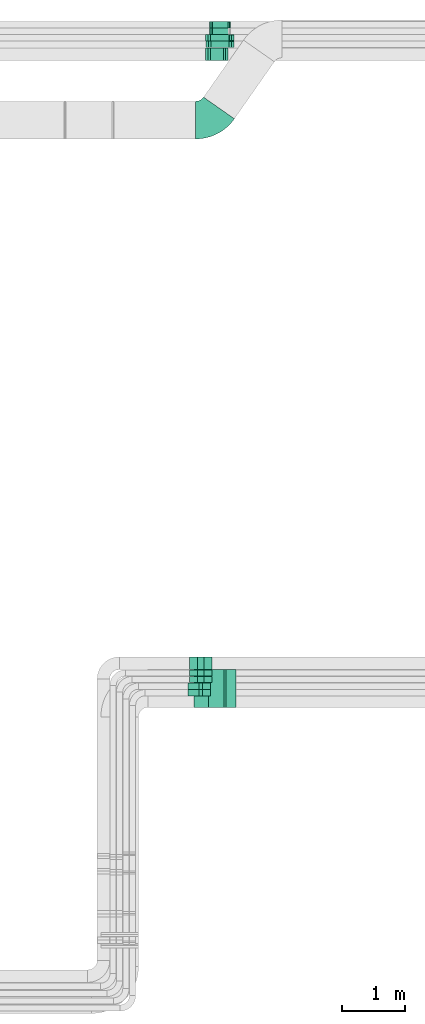
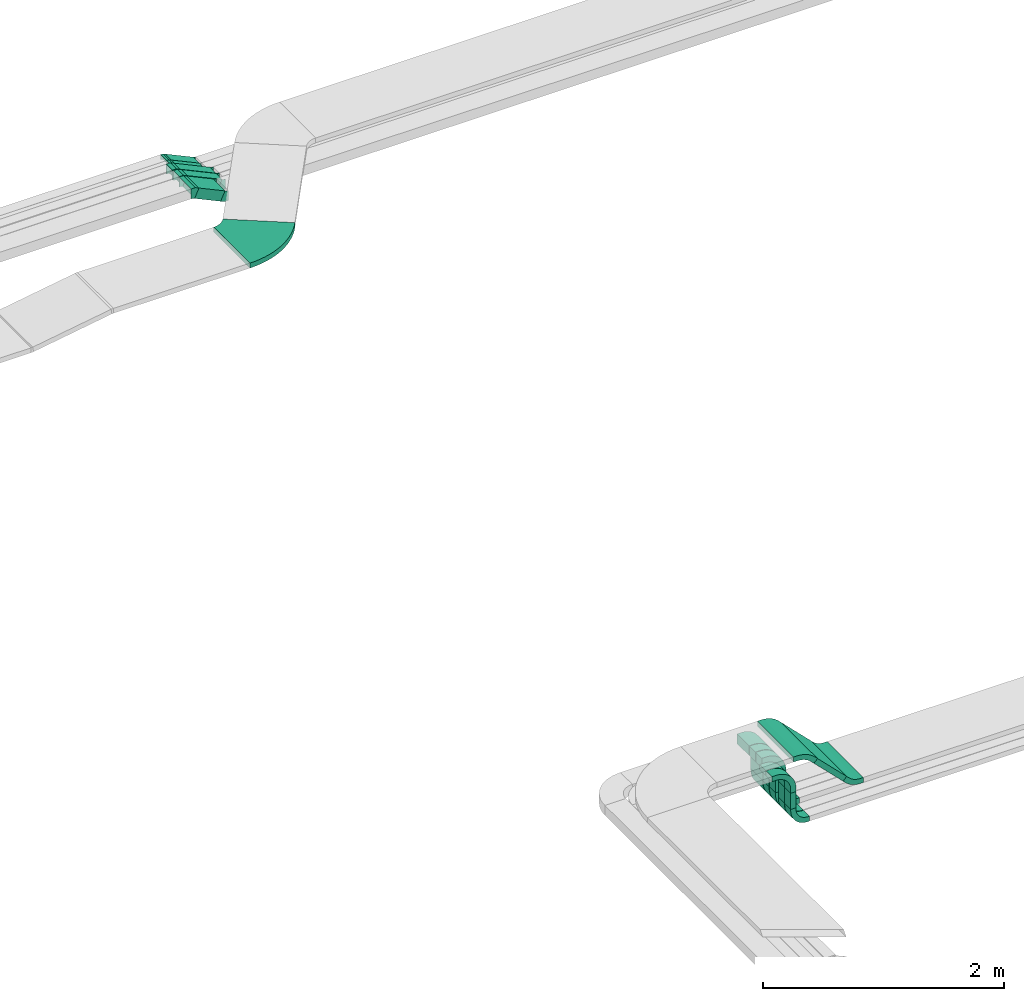
# One storey, part 20 of 28: 22 flow fittings, 11 flow segments.
"""IFC2X3 building model written with IfcOpenShell, lengths in millimetres."""

from ifc_helpers import new_model, entity, si_unit, converted_unit, derived_unit, direction, frame, frame_2d, origin, origin_2d_with_axis, place, context, subcontext, project, spatial, polyline, circle_curve, parameter, trimmed, segment, composite_curve, rectangle, outline, extrude, faceted_brep, source, transform, mapped, material, type_object, type_shapes, element, save


model = new_model("IFC2X3")

# Units and contexts
model_context = context("Model", 3, precision=0.01, world=origin(), true_north=direction((6.12303176911189e-17, 1.0)))
body_context = subcontext(model_context, "Body", "Model", "MODEL_VIEW")
ifc_project = project(units=[si_unit("LENGTHUNIT", "METRE", prefix="MILLI"), si_unit("AREAUNIT", "SQUARE_METRE"), si_unit("VOLUMEUNIT", "CUBIC_METRE"), converted_unit("PLANEANGLEUNIT", "DEGREE", entity("IfcRatioMeasure", 0.0174532925199433), si_unit("PLANEANGLEUNIT", "RADIAN"), dimensions=[0, 0, 0, 0, 0, 0, 0]), si_unit("MASSUNIT", "GRAM", prefix="KILO"), derived_unit("MASSDENSITYUNIT", [(si_unit("MASSUNIT", "GRAM", prefix="KILO"), 1), (si_unit("LENGTHUNIT", "METRE"), -3)]), derived_unit("MOMENTOFINERTIAUNIT", [(si_unit("LENGTHUNIT", "METRE"), 4)]), si_unit("TIMEUNIT", "SECOND"), si_unit("FREQUENCYUNIT", "HERTZ"), si_unit("THERMODYNAMICTEMPERATUREUNIT", "DEGREE_CELSIUS"), derived_unit("THERMALTRANSMITTANCEUNIT", [(si_unit("MASSUNIT", "GRAM", prefix="KILO"), 1), (si_unit("THERMODYNAMICTEMPERATUREUNIT", "KELVIN"), -1), (si_unit("TIMEUNIT", "SECOND"), -3)]), derived_unit("VOLUMETRICFLOWRATEUNIT", [(si_unit("LENGTHUNIT", "METRE"), 3), (si_unit("TIMEUNIT", "SECOND"), -1)]), derived_unit("MASSFLOWRATEUNIT", [(si_unit("MASSUNIT", "GRAM", prefix="KILO"), 1), (si_unit("TIMEUNIT", "SECOND"), -1)]), derived_unit("ROTATIONALFREQUENCYUNIT", [(si_unit("TIMEUNIT", "SECOND"), -1)]), si_unit("ELECTRICCURRENTUNIT", "AMPERE"), si_unit("ELECTRICVOLTAGEUNIT", "VOLT"), si_unit("POWERUNIT", "WATT"), si_unit("FORCEUNIT", "NEWTON", prefix="KILO"), si_unit("ILLUMINANCEUNIT", "LUX"), si_unit("LUMINOUSFLUXUNIT", "LUMEN"), si_unit("LUMINOUSINTENSITYUNIT", "CANDELA"), derived_unit("USERDEFINED", [(si_unit("MASSUNIT", "GRAM", prefix="KILO"), -1), (si_unit("LENGTHUNIT", "METRE"), -2), (si_unit("TIMEUNIT", "SECOND"), 3), (si_unit("LUMINOUSFLUXUNIT", "LUMEN"), 1)]), derived_unit("LINEARVELOCITYUNIT", [(si_unit("LENGTHUNIT", "METRE"), 1), (si_unit("TIMEUNIT", "SECOND"), -1)]), si_unit("PRESSUREUNIT", "PASCAL"), derived_unit("USERDEFINED", [(si_unit("LENGTHUNIT", "METRE"), -2), (si_unit("MASSUNIT", "GRAM", prefix="KILO"), 1), (si_unit("TIMEUNIT", "SECOND"), -2)]), derived_unit("LINEARFORCEUNIT", [(si_unit("MASSUNIT", "GRAM", prefix="KILO"), 1), (si_unit("LENGTHUNIT", "METRE"), 1), (si_unit("TIMEUNIT", "SECOND"), -2), (si_unit("LENGTHUNIT", "METRE"), -1)]), derived_unit("PLANARFORCEUNIT", [(si_unit("MASSUNIT", "GRAM", prefix="KILO"), 1), (si_unit("LENGTHUNIT", "METRE"), 1), (si_unit("TIMEUNIT", "SECOND"), -2), (si_unit("LENGTHUNIT", "METRE"), -2)])], contexts=[model_context])

# Site, building, storey
site_placement = place(None, origin())
site = spatial("IfcSite", under=ifc_project, at=site_placement, CompositionType="ELEMENT")
building_placement = place(site_placement, origin())
building = spatial("IfcBuilding", under=site, at=building_placement, CompositionType="ELEMENT")
storey_placement = place(building_placement, frame((0.0, 0.0, 4200.0)))
storey = spatial("IfcBuildingStorey", under=building, at=storey_placement, CompositionType="ELEMENT", Elevation=4200.0)

# Flow segments
cable_carrier_segment_type = type_object("IfcCableCarrierSegmentType", PredefinedType="CABLETRAYSEGMENT")
flow_segment_1_placement = place(storey_placement, frame((40491.87, 5216.66, 2940.27)))
element("IfcFlowSegment", 1, at=flow_segment_1_placement, inside=storey, type_object=cable_carrier_segment_type, context=body_context, shape_type="SweptSolid", body=[
    extrude(rectangle(XDim=394.712516352665, YDim=49.9999999999872, at=origin_2d_with_axis()), frame((157.23, 0.0, 157.23), z_axis=(0.0, 1.0, 0.0), x_axis=(0.707106781186491, 0.0, -0.707106781186604)), (0.0, 0.0, 1.0), 600.0),
])
for number, where in (
    (2, (40376.18, 5400.19, 2680.0)),
    (3, (40376.18, 5505.19, 2680.0)),
):
    element("IfcFlowSegment", number, at=place(storey_placement, frame(where)), inside=storey, type_object=cable_carrier_segment_type, context=body_context, shape_type="SweptSolid", body=[
        extrude(rectangle(XDim=99.9999999999989, YDim=50.000000000006, at=origin_2d_with_axis()), frame((25.0, 50.0, 0.0), z_axis=(0.0, 0.0, 1.0), x_axis=(0.0, -1.0, 0.0)), (0.0, 0.0, 1.0), 165.00000000001),
    ])
flow_segment_2_placement = place(storey_placement, frame((40351.18, 5610.19, 2730.0)))
element("IfcFlowSegment", 4, at=flow_segment_2_placement, inside=storey, type_object=cable_carrier_segment_type, context=body_context, shape_type="SweptSolid", body=[
    extrude(rectangle(XDim=100.000000000001, YDim=99.9999999999946, at=origin_2d_with_axis()), frame((50.0, 50.0, 0.0), z_axis=(0.0, 0.0, 1.0), x_axis=(0.0, -1.0, 0.0)), (0.0, 0.0, 1.0), 165.000000000004),
])
flow_segment_3_placement = place(storey_placement, frame((40351.18, 5715.19, 2730.0)))
element("IfcFlowSegment", 5, at=flow_segment_3_placement, inside=storey, type_object=cable_carrier_segment_type, context=body_context, shape_type="SweptSolid", body=[
    extrude(rectangle(XDim=99.9999999999989, YDim=99.9999999999946, at=origin_2d_with_axis()), frame((50.0, 50.0, 0.0), z_axis=(0.0, 0.0, 1.0), x_axis=(0.0, -1.0, 0.0)), (0.0, 0.0, 1.0), 164.999999999999),
])
flow_segment_4_placement = place(storey_placement, frame((40351.18, 5820.37, 2730.0)))
element("IfcFlowSegment", 6, at=flow_segment_4_placement, inside=storey, type_object=cable_carrier_segment_type, context=body_context, shape_type="SweptSolid", body=[
    extrude(rectangle(XDim=200.0, YDim=99.9999999999946, at=origin_2d_with_axis()), frame((50.0, 100.0, 0.0), z_axis=(0.0, 0.0, 1.0), x_axis=(0.0, -1.0, 0.0)), (0.0, 0.0, 1.0), 165.000000000017),
])
flow_segment_5_placement = place(storey_placement, frame((40513.14, 15519.49, 2563.34)))
element("IfcFlowSegment", 7, at=flow_segment_5_placement, inside=storey, type_object=cable_carrier_segment_type, context=body_context, shape_type="SweptSolid", body=[
    extrude(rectangle(XDim=100.000000000005, YDim=200.000000000002, at=origin_2d_with_axis()), frame((21.13, 100.0, 161.41), z_axis=(0.906307787036662, 0.0, -0.422618261740674), x_axis=(0.422618261740674, 0.0, 0.906307787036662)), (0.0, 0.0, 1.0), 274.712342486454),
])
flow_segment_6_placement = place(storey_placement, frame((40522.14, 15728.42, 2520.51)))
element("IfcFlowSegment", 8, at=flow_segment_6_placement, inside=storey, type_object=cable_carrier_segment_type, context=body_context, shape_type="SweptSolid", body=[
    extrude(rectangle(XDim=99.9999999999933, YDim=99.9999999999989, at=origin_2d_with_axis()), frame((21.13, 50.0, 200.05), z_axis=(0.90630778703668, 0.0, -0.422618261740636), x_axis=(0.422618261740636, 0.0, 0.90630778703668)), (0.0, 0.0, 1.0), 366.132160564234),
])
flow_segment_7_placement = place(storey_placement, frame((40513.14, 15833.42, 2520.07)))
element("IfcFlowSegment", 9, at=flow_segment_7_placement, inside=storey, type_object=cable_carrier_segment_type, context=body_context, shape_type="SweptSolid", body=[
    extrude(rectangle(XDim=99.9999999999969, YDim=99.9999999999989, at=origin_2d_with_axis()), frame((21.13, 50.0, 204.68), z_axis=(0.906307787036647, 0.0, -0.422618261740707), x_axis=(0.422618261740707, 0.0, 0.906307787036647)), (0.0, 0.0, 1.0), 377.094354823424),
])
flow_segment_8_placement = place(storey_placement, frame((40567.27, 15938.42, 2556.31)))
element("IfcFlowSegment", 10, at=flow_segment_8_placement, inside=storey, type_object=cable_carrier_segment_type, context=body_context, shape_type="SweptSolid", body=[
    extrude(rectangle(XDim=50.0000000000057, YDim=99.9999999999989, at=origin_2d_with_axis()), frame((10.57, 50.0, 148.13), z_axis=(0.906307787036635, 0.0, -0.422618261740732), x_axis=(0.422618261740732, 0.0, 0.906307787036635)), (0.0, 0.0, 1.0), 296.896682553644),
])
flow_segment_9_placement = place(storey_placement, frame((40567.27, 16039.18, 2556.31)))
element("IfcFlowSegment", 11, at=flow_segment_9_placement, inside=storey, type_object=cable_carrier_segment_type, context=body_context, shape_type="SweptSolid", body=[
    extrude(rectangle(XDim=50.0000000000047, YDim=99.9999999999989, at=origin_2d_with_axis()), frame((10.57, 50.0, 148.13), z_axis=(0.906307787036631, 0.0, -0.422618261740741), x_axis=(0.422618261740741, 0.0, 0.906307787036631)), (0.0, 0.0, 1.0), 296.881808750623),
])

# Flow fittings
ifc_material = material()
cable_carrier_fitting_type_1 = type_object("IfcCableCarrierFittingType", PredefinedType="NOTDEFINED", material=ifc_material)
shared_shape_1 = source(origin(), body_context, "Body", "Brep", [
    faceted_brep([(-28.28, -50.0, 100.0), (-28.28, 50.0, 100.0), (-28.28, 50.0, 97.46), (-28.28, -47.46, 97.46), (-28.28, -47.46, -97.46), (-28.28, 50.0, -97.46), (-28.28, 50.0, -100.0), (-28.28, -50.0, -100.0), (46.76, -33.36, 100.0), (46.76, -33.36, -100.0), (4.5, 57.27, -100.0), (4.5, 57.27, -97.46), (45.69, -31.06, -97.46), (45.69, -31.06, 97.46), (4.5, 57.27, 97.46), (4.5, 57.27, 100.0), (11.08, -50.0, 100.0), (-11.08, 50.0, 100.0), (-11.08, 50.0, 97.46), (10.52, -47.46, 97.46), (10.52, -47.46, -97.46), (-11.08, 50.0, -97.46), (-11.08, 50.0, -100.0), (11.08, -50.0, -100.0)], [[[0, 1, 2, 3, 4, 5, 6, 7]], [[8, 9, 10, 11, 12, 13, 14, 15]], [[1, 0, 16, 8, 15, 17]], [[2, 1, 17, 18]], [[3, 2, 18, 14, 13, 19]], [[4, 3, 19, 20]], [[5, 4, 20, 12, 11, 21]], [[6, 5, 21, 22]], [[7, 6, 22, 10, 9, 23]], [[0, 7, 23, 16]], [[18, 17, 15, 14]], [[20, 19, 13, 12]], [[22, 21, 11, 10]], [[16, 23, 9, 8]]]),
])
type_shapes(cable_carrier_fitting_type_1, [shared_shape_1])
for number, where, z_axis, x_axis in (
    (12, (40808.87, 15619.49, 2596.71), (0.0, 1.0, 0.0), (-1.0, 0.0, 0.0)),
    (13, (40508.64, 15619.49, 2736.71), (0.0, -1.0, 0.0), (-0.906307787036659, 0.0, 0.42261826174068)),
):
    element("IfcFlowFitting", number, at=place(storey_placement, frame(where, z_axis=z_axis, x_axis=x_axis)), inside=storey, type_object=cable_carrier_fitting_type_1, material=ifc_material, context=body_context, shape_type="MappedRepresentation", body=[
        mapped(shared_shape_1, transform((0.0, 0.0, 0.0), scale=1.0)),
    ])
cable_carrier_fitting_type_2 = type_object("IfcCableCarrierFittingType", PredefinedType="NOTDEFINED", material=ifc_material)
shared_shape_2 = source(origin(), body_context, "Body", "Brep", [
    faceted_brep([(-28.28, -50.0, 50.0), (-28.28, 50.0, 50.0), (-28.28, 50.0, 47.46), (-28.28, -47.46, 47.46), (-28.28, -47.46, -47.46), (-28.28, 50.0, -47.46), (-28.28, 50.0, -50.0), (-28.28, -50.0, -50.0), (46.76, -33.36, 50.0), (46.76, -33.36, -50.0), (4.5, 57.27, -50.0), (4.5, 57.27, -47.46), (45.69, -31.06, -47.46), (45.69, -31.06, 47.46), (4.5, 57.27, 47.46), (4.5, 57.27, 50.0), (11.08, -50.0, 50.0), (-11.08, 50.0, 50.0), (-11.08, 50.0, 47.46), (10.52, -47.46, 47.46), (10.52, -47.46, -47.46), (-11.08, 50.0, -47.46), (-11.08, 50.0, -50.0), (11.08, -50.0, -50.0)], [[[0, 1, 2, 3, 4, 5, 6, 7]], [[8, 9, 10, 11, 12, 13, 14, 15]], [[1, 0, 16, 8, 15, 17]], [[2, 1, 17, 18]], [[3, 2, 18, 14, 13, 19]], [[4, 3, 19, 20]], [[5, 4, 20, 12, 11, 21]], [[6, 5, 21, 22]], [[7, 6, 22, 10, 9, 23]], [[0, 7, 23, 16]], [[18, 17, 15, 14]], [[20, 19, 13, 12]], [[22, 21, 11, 10]], [[16, 23, 9, 8]]]),
])
type_shapes(cable_carrier_fitting_type_2, [shared_shape_2])
for number, where, z_axis, x_axis in (
    (14, (40900.72, 15778.42, 2553.87), (0.0, -1.0, 0.0), (0.906307787036655, 0.0, -0.422618261740689)),
    (15, (40517.64, 15778.42, 2732.51), (0.0, -1.0, 0.0), (-0.906307787036656, 0.0, 0.422618261740687)),
    (16, (40901.66, 15883.42, 2553.44), (0.0, -1.0, 0.0), (0.906307787036657, 0.0, -0.422618261740685)),
    (17, (40508.64, 15883.42, 2736.71), (0.0, -1.0, 0.0), (-0.906307787036657, 0.0, 0.422618261740684)),
):
    element("IfcFlowFitting", number, at=place(storey_placement, frame(where, z_axis=z_axis, x_axis=x_axis)), inside=storey, type_object=cable_carrier_fitting_type_2, material=ifc_material, context=body_context, shape_type="MappedRepresentation", body=[
        mapped(shared_shape_2, transform((0.0, 0.0, 0.0), scale=1.0)),
    ])
cable_carrier_fitting_type_3 = type_object("IfcCableCarrierFittingType", PredefinedType="NOTDEFINED", material=ifc_material)
shared_shape_3 = source(origin(), body_context, "Body", "Brep", [
    faceted_brep([(-17.19, -25.0, 50.0), (-17.19, 25.0, 50.0), (-17.19, 25.0, 47.46), (-17.19, -22.46, 47.46), (-17.19, -22.46, -47.46), (-17.19, 25.0, -47.46), (-17.19, 25.0, -50.0), (-17.19, -25.0, -50.0), (26.15, -15.39, 50.0), (26.15, -15.39, -50.0), (5.02, 29.92, -50.0), (5.02, 29.92, -47.46), (25.07, -13.09, -47.46), (25.07, -13.09, 47.46), (5.02, 29.92, 47.46), (5.02, 29.92, 50.0), (5.54, -25.0, 50.0), (-5.54, 25.0, 50.0), (-5.54, 25.0, 47.46), (4.98, -22.46, 47.46), (4.98, -22.46, -47.46), (-5.54, 25.0, -47.46), (-5.54, 25.0, -50.0), (5.54, -25.0, -50.0)], [[[0, 1, 2, 3, 4, 5, 6, 7]], [[8, 9, 10, 11, 12, 13, 14, 15]], [[1, 0, 16, 8, 15, 17]], [[2, 1, 17, 18]], [[3, 2, 18, 14, 13, 19]], [[4, 3, 19, 20]], [[5, 4, 20, 12, 11, 21]], [[6, 5, 21, 22]], [[7, 6, 22, 10, 9, 23]], [[0, 7, 23, 16]], [[18, 17, 15, 14]], [[20, 19, 13, 12]], [[22, 21, 11, 10]], [[16, 23, 9, 8]]]),
])
type_shapes(cable_carrier_fitting_type_3, [shared_shape_3])
for number, where, z_axis, x_axis in (
    (18, (40862.48, 16089.18, 2571.71), (0.0, -1.0, 0.0), (0.906307787036659, 0.0, -0.42261826174068)),
    (19, (40562.25, 15988.42, 2711.71), (0.0, -1.0, 0.0), (-0.906307787036662, 0.0, 0.422618261740673)),
    (20, (40562.25, 16089.18, 2711.71), (0.0, -1.0, 0.0), (-0.906307787036652, 0.0, 0.422618261740696)),
):
    element("IfcFlowFitting", number, at=place(storey_placement, frame(where, z_axis=z_axis, x_axis=x_axis)), inside=storey, type_object=cable_carrier_fitting_type_3, material=ifc_material, context=body_context, shape_type="MappedRepresentation", body=[
        mapped(shared_shape_3, transform((0.0, 0.0, 0.0), scale=1.0)),
    ])
cable_carrier_fitting_type_4 = type_object("IfcCableCarrierFittingType", Name="470_DKC_S5_CD 90 external vertical angle:-", PredefinedType="NOTDEFINED", material=ifc_material)
shared_shape_4 = source(origin(), body_context, "Body", "SweptSolid", [
    extrude(outline(composite_curve([segment(polyline([(-100.0, -130.0), (-60.0, -130.0)]), True, "CONTINUOUS"), segment(trimmed(circle_curve(frame_2d((-60.0, 60.0), x_axis=(0.0, -1.0)), 189.999999999999), [parameter(0.0)], [parameter(90.0)], True, "PARAMETER"), True, "CONTINUOUS"), segment(polyline([(130.0, 60.0), (130.0, 100.0)]), True, "CONTINUOUS"), segment(polyline([(130.0, 100.0), (30.0, 100.0)]), True, "CONTINUOUS"), segment(polyline([(30.0, 100.0), (30.0, 60.0)]), True, "CONTINUOUS"), segment(trimmed(circle_curve(frame_2d((-60.0, 60.0), x_axis=(0.0, -1.0)), 89.9999999999988), [parameter(0.0)], [parameter(90.0)], True, "PARAMETER"), False, "CONTINUOUS"), segment(polyline([(-60.0, -30.0), (-100.0, -30.0)]), True, "CONTINUOUS"), segment(polyline([(-100.0, -30.0), (-100.0, -130.0)]), True, "CONTINUOUS")], self_intersect=False)), frame((-80.0, 80.0, -50.0)), (0.0, 0.0, 1.0), 99.9999999999999),
])
type_shapes(cable_carrier_fitting_type_4, [shared_shape_4])
for number, where, z_axis, x_axis, name in (
    (21, (40401.18, 5660.19, 3075.0), (0.0, -1.0, 0.0), (0.0, 0.0, 1.0), "470_DKC_S5_CD 90 external vertical angle:-"),
    (22, (40401.18, 5765.19, 3075.0), (0.0, -1.0, 0.0), (0.0, 0.0, 1.0), "470_DKC_S5_CD 90 external vertical angle:-"),
):
    element("IfcFlowFitting", number, at=place(storey_placement, frame(where, z_axis=z_axis, x_axis=x_axis)), inside=storey, type_object=cable_carrier_fitting_type_4, material=ifc_material, Name=name, ObjectType="470_DKC_S5_CD 90 external vertical angle:-", context=body_context, shape_type="MappedRepresentation", body=[
        mapped(shared_shape_4, transform((0.0, 0.0, 0.0), scale=1.0)),
    ])
cable_carrier_fitting_type_5 = type_object("IfcCableCarrierFittingType", Name="470_DKC_S5_Variable Angle Elbow 0-45:-", PredefinedType="NOTDEFINED", material=ifc_material)
shared_shape_5 = source(origin(), body_context, "Body", "SweptSolid", [
    extrude(outline(composite_curve([segment(polyline([(-185.2, -396.15), (-184.2, -396.15)]), True, "CONTINUOUS"), segment(trimmed(circle_curve(frame_2d((-184.2, 353.85), x_axis=(0.0, -1.0)), 750.0), [parameter(0.0)], [parameter(55.0)], True, "PARAMETER"), True, "CONTINUOUS"), segment(polyline([(430.16, -76.33), (430.74, -75.51)]), True, "CONTINUOUS"), segment(polyline([(430.74, -75.51), (-60.76, 268.63)]), True, "CONTINUOUS"), segment(polyline([(-60.76, 268.63), (-61.33, 267.81)]), True, "CONTINUOUS"), segment(trimmed(circle_curve(frame_2d((-184.2, 353.85), x_axis=(0.0, -1.0)), 150.0), [parameter(0.0)], [parameter(55.0)], True, "PARAMETER"), False, "CONTINUOUS"), segment(polyline([(-184.2, 203.85), (-185.2, 203.85)]), True, "CONTINUOUS"), segment(polyline([(-185.2, 203.85), (-185.2, -396.15)]), True, "CONTINUOUS")], self_intersect=False)), frame((-50.05, 96.15, -25.0)), (0.0, 0.0, 1.0), 50.0000000000068),
])
type_shapes(cable_carrier_fitting_type_5, [shared_shape_5])
flow_fitting_1_placement = place(storey_placement, frame((40557.3, 14571.85, 2823.17)))
element("IfcFlowFitting", 23, at=flow_fitting_1_placement, inside=storey, type_object=cable_carrier_fitting_type_5, material=ifc_material, Name="470_DKC_S5_Variable Angle Elbow 0-45:-", ObjectType="470_DKC_S5_Variable Angle Elbow 0-45:-", context=body_context, shape_type="MappedRepresentation", body=[
    mapped(shared_shape_5, transform((0.0, 0.0, 0.0), scale=1.0)),
])
cable_carrier_fitting_type_6 = type_object("IfcCableCarrierFittingType", Name="470_DKC_S5_CD 90 external vertical angle:-", PredefinedType="NOTDEFINED", material=ifc_material)
shared_shape_6 = source(origin(), body_context, "Body", "SweptSolid", [
    extrude(outline(composite_curve([segment(polyline([(-108.75, -62.73), (-73.43, -62.73)]), True, "CONTINUOUS"), segment(trimmed(circle_curve(frame_2d((-73.43, 177.27), x_axis=(0.0, -1.0)), 239.999999999999), [parameter(0.0)], [parameter(45.0)], True, "PARAMETER"), True, "CONTINUOUS"), segment(polyline([(96.28, 7.56), (121.25, 32.54)]), True, "CONTINUOUS"), segment(polyline([(121.25, 32.54), (85.9, 67.89)]), True, "CONTINUOUS"), segment(polyline([(85.9, 67.89), (60.92, 42.92)]), True, "CONTINUOUS"), segment(trimmed(circle_curve(frame_2d((-73.43, 177.27), x_axis=(0.0, -1.0)), 189.999999999999), [parameter(0.0)], [parameter(45.0)], True, "PARAMETER"), False, "CONTINUOUS"), segment(polyline([(-73.43, -12.73), (-108.75, -12.73)]), True, "CONTINUOUS"), segment(polyline([(-108.75, -12.73), (-108.75, -62.73)]), True, "CONTINUOUS")], self_intersect=False)), frame((-15.63, 37.73, -300.0)), (0.0, 0.0, 1.0), 600.0),
])
type_shapes(cable_carrier_fitting_type_6, [shared_shape_6])
flow_fitting_2_placement = place(storey_placement, frame((40421.6, 5516.66, 3325.0), z_axis=(0.0, 1.0, 0.0), x_axis=(1.0, 0.0, 0.0)))
element("IfcFlowFitting", 24, at=flow_fitting_2_placement, inside=storey, type_object=cable_carrier_fitting_type_6, material=ifc_material, Name="470_DKC_S5_CD 90 external vertical angle:-", ObjectType="470_DKC_S5_CD 90 external vertical angle:-", context=body_context, shape_type="MappedRepresentation", body=[
    mapped(shared_shape_6, transform((0.0, 0.0, 0.0), scale=1.0)),
])
cable_carrier_fitting_type_7 = type_object("IfcCableCarrierFittingType", Name="470_DKC_S5_CD 90 external vertical angle:-", PredefinedType="NOTDEFINED", material=ifc_material)
shared_shape_7 = source(origin(), body_context, "Body", "SweptSolid", [
    extrude(outline(composite_curve([segment(polyline([(-112.5, -117.5), (-72.5, -117.5)]), True, "CONTINUOUS"), segment(trimmed(circle_curve(frame_2d((-72.5, 72.5), x_axis=(0.0, -1.0)), 189.999999999999), [parameter(0.0)], [parameter(90.0)], True, "PARAMETER"), True, "CONTINUOUS"), segment(polyline([(117.5, 72.5), (117.5, 112.5)]), True, "CONTINUOUS"), segment(polyline([(117.5, 112.5), (67.5, 112.5)]), True, "CONTINUOUS"), segment(polyline([(67.5, 112.5), (67.5, 72.5)]), True, "CONTINUOUS"), segment(trimmed(circle_curve(frame_2d((-72.5, 72.5), x_axis=(0.0, -1.0)), 139.999999999999), [parameter(0.0)], [parameter(90.0)], True, "PARAMETER"), False, "CONTINUOUS"), segment(polyline([(-72.5, -67.5), (-112.5, -67.5)]), True, "CONTINUOUS"), segment(polyline([(-112.5, -67.5), (-112.5, -117.5)]), True, "CONTINUOUS")], self_intersect=False)), frame((-92.5, 92.5, -50.0)), (0.0, 0.0, 1.0), 99.9999999999999),
])
type_shapes(cable_carrier_fitting_type_7, [shared_shape_7])
for number, where, z_axis, x_axis, name in (
    (25, (40401.18, 5450.19, 3050.0), (0.0, -1.0, 0.0), (0.0, 0.0, 1.0), "470_DKC_S5_CD 90 external vertical angle:-"),
    (26, (40401.18, 5555.19, 3050.0), (0.0, -1.0, 0.0), (0.0, 0.0, 1.0), "470_DKC_S5_CD 90 external vertical angle:-"),
):
    element("IfcFlowFitting", number, at=place(storey_placement, frame(where, z_axis=z_axis, x_axis=x_axis)), inside=storey, type_object=cable_carrier_fitting_type_7, material=ifc_material, Name=name, ObjectType="470_DKC_S5_CD 90 external vertical angle:-", context=body_context, shape_type="MappedRepresentation", body=[
        mapped(shared_shape_7, transform((0.0, 0.0, 0.0), scale=1.0)),
    ])
cable_carrier_fitting_type_8 = type_object("IfcCableCarrierFittingType", Name="470_DKC_S5_CS 90 internal vertical angle:-", PredefinedType="NOTDEFINED", material=ifc_material)
shared_shape_8 = source(origin(), body_context, "Body", "SweptSolid", [
    extrude(outline(composite_curve([segment(polyline([(-81.25, -98.75), (-66.25, -98.75)]), True, "CONTINUOUS"), segment(trimmed(circle_curve(frame_2d((-66.25, 66.25), x_axis=(0.0, -1.0)), 164.999999999999), [parameter(0.0)], [parameter(90.0)], True, "PARAMETER"), True, "CONTINUOUS"), segment(polyline([(98.75, 66.25), (98.75, 81.25)]), True, "CONTINUOUS"), segment(polyline([(98.75, 81.25), (48.75, 81.25)]), True, "CONTINUOUS"), segment(polyline([(48.75, 81.25), (48.75, 66.25)]), True, "CONTINUOUS"), segment(trimmed(circle_curve(frame_2d((-66.25, 66.25), x_axis=(0.0, -1.0)), 114.999999999999), [parameter(0.0)], [parameter(90.0)], True, "PARAMETER"), False, "CONTINUOUS"), segment(polyline([(-66.25, -48.75), (-81.25, -48.75)]), True, "CONTINUOUS"), segment(polyline([(-81.25, -48.75), (-81.25, -98.75)]), True, "CONTINUOUS")], self_intersect=False)), frame((-73.75, 73.75, -50.0)), (0.0, 0.0, 1.0), 99.9999999999999),
])
type_shapes(cable_carrier_fitting_type_8, [shared_shape_8])
for number, where, z_axis, x_axis, name in (
    (27, (40401.18, 5555.19, 2525.0), (0.0, -1.0, 0.0), (0.0, 0.0, -1.0), "470_DKC_S5_CS 90 internal vertical angle:-"),
    (28, (40401.18, 5450.19, 2525.0), (0.0, -1.0, 0.0), (0.0, 0.0, -1.0), "470_DKC_S5_CS 90 internal vertical angle:-"),
):
    element("IfcFlowFitting", number, at=place(storey_placement, frame(where, z_axis=z_axis, x_axis=x_axis)), inside=storey, type_object=cable_carrier_fitting_type_8, material=ifc_material, Name=name, ObjectType="470_DKC_S5_CS 90 internal vertical angle:-", context=body_context, shape_type="MappedRepresentation", body=[
        mapped(shared_shape_8, transform((0.0, 0.0, 0.0), scale=1.0)),
    ])
cable_carrier_fitting_type_9 = type_object("IfcCableCarrierFittingType", Name="470_DKC_S5_CS 90 internal vertical angle:-", PredefinedType="NOTDEFINED", material=ifc_material)
shared_shape_9 = source(origin(), body_context, "Body", "SweptSolid", [
    extrude(outline(composite_curve([segment(polyline([(-93.75, -136.25), (-78.75, -136.25)]), True, "CONTINUOUS"), segment(trimmed(circle_curve(frame_2d((-78.75, 78.75), x_axis=(0.0, -1.0)), 214.999999999999), [parameter(0.0)], [parameter(90.0)], True, "PARAMETER"), True, "CONTINUOUS"), segment(polyline([(136.25, 78.75), (136.25, 93.75)]), True, "CONTINUOUS"), segment(polyline([(136.25, 93.75), (36.25, 93.75)]), True, "CONTINUOUS"), segment(polyline([(36.25, 93.75), (36.25, 78.75)]), True, "CONTINUOUS"), segment(trimmed(circle_curve(frame_2d((-78.75, 78.75), x_axis=(0.0, -1.0)), 114.999999999999), [parameter(0.0)], [parameter(90.0)], True, "PARAMETER"), False, "CONTINUOUS"), segment(polyline([(-78.75, -36.25), (-93.75, -36.25)]), True, "CONTINUOUS"), segment(polyline([(-93.75, -36.25), (-93.75, -136.25)]), True, "CONTINUOUS")], self_intersect=False)), frame((-86.25, 86.25, -50.0)), (0.0, 0.0, 1.0), 99.9999999999999),
])
type_shapes(cable_carrier_fitting_type_9, [shared_shape_9])
for number, where, z_axis, x_axis, name in (
    (29, (40401.18, 5660.19, 2550.0), (0.0, -1.0, 0.0), (0.0, 0.0, -1.0), "470_DKC_S5_CS 90 internal vertical angle:-"),
    (30, (40401.18, 5765.19, 2550.0), (0.0, -1.0, 0.0), (0.0, 0.0, -1.0), "470_DKC_S5_CS 90 internal vertical angle:-"),
):
    element("IfcFlowFitting", number, at=place(storey_placement, frame(where, z_axis=z_axis, x_axis=x_axis)), inside=storey, type_object=cable_carrier_fitting_type_9, material=ifc_material, Name=name, ObjectType="470_DKC_S5_CS 90 internal vertical angle:-", context=body_context, shape_type="MappedRepresentation", body=[
        mapped(shared_shape_9, transform((0.0, 0.0, 0.0), scale=1.0)),
    ])
cable_carrier_fitting_type_10 = type_object("IfcCableCarrierFittingType", Name="470_DKC_S5_CD 90 external vertical angle:-", PredefinedType="NOTDEFINED", material=ifc_material)
shared_shape_10 = source(origin(), body_context, "Body", "SweptSolid", [
    extrude(outline(composite_curve([segment(polyline([(-100.0, -130.0), (-60.0, -130.0)]), True, "CONTINUOUS"), segment(trimmed(circle_curve(frame_2d((-60.0, 60.0), x_axis=(0.0, -1.0)), 189.999999999999), [parameter(0.0)], [parameter(90.0)], True, "PARAMETER"), True, "CONTINUOUS"), segment(polyline([(130.0, 60.0), (130.0, 100.0)]), True, "CONTINUOUS"), segment(polyline([(130.0, 100.0), (30.0, 100.0)]), True, "CONTINUOUS"), segment(polyline([(30.0, 100.0), (30.0, 60.0)]), True, "CONTINUOUS"), segment(trimmed(circle_curve(frame_2d((-60.0, 60.0), x_axis=(0.0, -1.0)), 89.9999999999988), [parameter(0.0)], [parameter(90.0)], True, "PARAMETER"), False, "CONTINUOUS"), segment(polyline([(-60.0, -30.0), (-100.0, -30.0)]), True, "CONTINUOUS"), segment(polyline([(-100.0, -30.0), (-100.0, -130.0)]), True, "CONTINUOUS")], self_intersect=False)), frame((-80.0, 80.0, -100.0)), (0.0, 0.0, 1.0), 200.0),
])
type_shapes(cable_carrier_fitting_type_10, [shared_shape_10])
flow_fitting_3_placement = place(storey_placement, frame((40401.18, 5920.19, 3075.0), z_axis=(0.0, -1.0, 0.0), x_axis=(0.0, 0.0, 1.0)))
element("IfcFlowFitting", 31, at=flow_fitting_3_placement, inside=storey, type_object=cable_carrier_fitting_type_10, material=ifc_material, Name="470_DKC_S5_CD 90 external vertical angle:-", ObjectType="470_DKC_S5_CD 90 external vertical angle:-", context=body_context, shape_type="MappedRepresentation", body=[
    mapped(shared_shape_10, transform((0.0, 0.0, 0.0), scale=1.0)),
])
cable_carrier_fitting_type_11 = type_object("IfcCableCarrierFittingType", Name="470_DKC_S5_CS 90 internal vertical angle:-", PredefinedType="NOTDEFINED", material=ifc_material)
shared_shape_11 = source(origin(), body_context, "Body", "SweptSolid", [
    extrude(outline(composite_curve([segment(polyline([(-93.75, -136.25), (-78.75, -136.25)]), True, "CONTINUOUS"), segment(trimmed(circle_curve(frame_2d((-78.75, 78.75), x_axis=(0.0, -1.0)), 214.999999999999), [parameter(0.0)], [parameter(90.0)], True, "PARAMETER"), True, "CONTINUOUS"), segment(polyline([(136.25, 78.75), (136.25, 93.75)]), True, "CONTINUOUS"), segment(polyline([(136.25, 93.75), (36.25, 93.75)]), True, "CONTINUOUS"), segment(polyline([(36.25, 93.75), (36.25, 78.75)]), True, "CONTINUOUS"), segment(trimmed(circle_curve(frame_2d((-78.75, 78.75), x_axis=(0.0, -1.0)), 114.999999999999), [parameter(0.0)], [parameter(90.0)], True, "PARAMETER"), False, "CONTINUOUS"), segment(polyline([(-78.75, -36.25), (-93.75, -36.25)]), True, "CONTINUOUS"), segment(polyline([(-93.75, -36.25), (-93.75, -136.25)]), True, "CONTINUOUS")], self_intersect=False)), frame((-86.25, 86.25, -100.0)), (0.0, 0.0, 1.0), 200.0),
])
type_shapes(cable_carrier_fitting_type_11, [shared_shape_11])
flow_fitting_4_placement = place(storey_placement, frame((40401.18, 5920.37, 2550.0), z_axis=(0.0, -1.0, 0.0), x_axis=(0.0, 0.0, -1.0)))
element("IfcFlowFitting", 32, at=flow_fitting_4_placement, inside=storey, type_object=cable_carrier_fitting_type_11, material=ifc_material, Name="470_DKC_S5_CS 90 internal vertical angle:-", ObjectType="470_DKC_S5_CS 90 internal vertical angle:-", context=body_context, shape_type="MappedRepresentation", body=[
    mapped(shared_shape_11, transform((0.0, 0.0, 0.0), scale=1.0)),
])
cable_carrier_fitting_type_12 = type_object("IfcCableCarrierFittingType", Name="470_DKC_S5_CS 90 internal vertical angle:-", PredefinedType="NOTDEFINED", material=ifc_material)
shared_shape_12 = source(origin(), body_context, "Body", "SweptSolid", [
    extrude(outline(composite_curve([segment(polyline([(-90.96, -56.18), (-59.57, -56.18)]), True, "CONTINUOUS"), segment(trimmed(circle_curve(frame_2d((-59.57, 143.82), x_axis=(0.0, -1.0)), 199.999999999999), [parameter(0.0)], [parameter(45.0)], True, "PARAMETER"), True, "CONTINUOUS"), segment(polyline([(81.85, 2.4), (104.04, 24.6)]), True, "CONTINUOUS"), segment(polyline([(104.04, 24.6), (68.69, 59.95)]), True, "CONTINUOUS"), segment(polyline([(68.69, 59.95), (46.49, 37.76)]), True, "CONTINUOUS"), segment(trimmed(circle_curve(frame_2d((-59.57, 143.82), x_axis=(0.0, -1.0)), 149.999999999999), [parameter(0.0)], [parameter(45.0)], True, "PARAMETER"), False, "CONTINUOUS"), segment(polyline([(-59.57, -6.18), (-90.96, -6.18)]), True, "CONTINUOUS"), segment(polyline([(-90.96, -6.18), (-90.96, -56.18)]), True, "CONTINUOUS")], self_intersect=False)), frame((-12.91, 31.18, -300.0)), (0.0, 0.0, 1.0), 600.0),
])
type_shapes(cable_carrier_fitting_type_12, [shared_shape_12])
flow_fitting_5_placement = place(storey_placement, frame((40862.1, 5516.66, 2884.5), z_axis=(0.0, -1.0, 0.0), x_axis=(0.707106781186511, 0.0, -0.707106781186584)))
element("IfcFlowFitting", 33, at=flow_fitting_5_placement, inside=storey, type_object=cable_carrier_fitting_type_12, material=ifc_material, Name="470_DKC_S5_CS 90 internal vertical angle:-", ObjectType="470_DKC_S5_CS 90 internal vertical angle:-", context=body_context, shape_type="MappedRepresentation", body=[
    mapped(shared_shape_12, transform((0.0, 0.0, 0.0), scale=1.0)),
])

save(model, "model.ifc")
